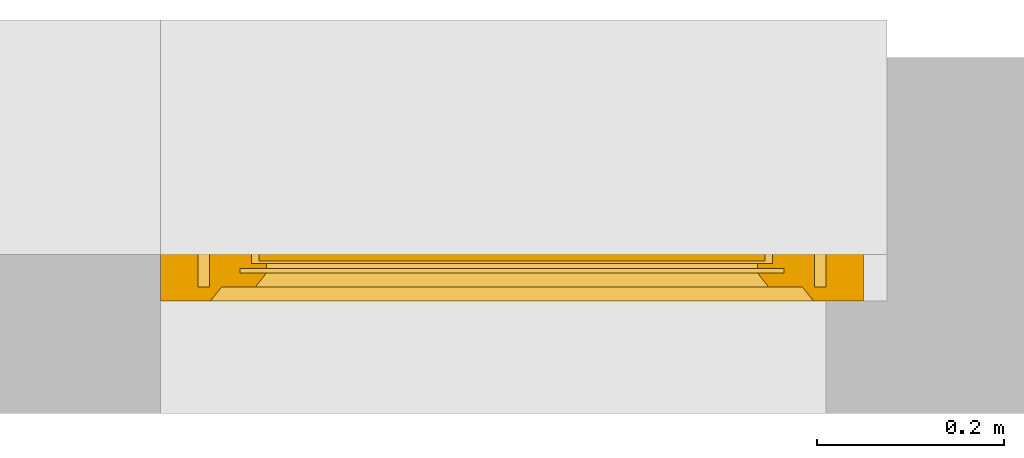
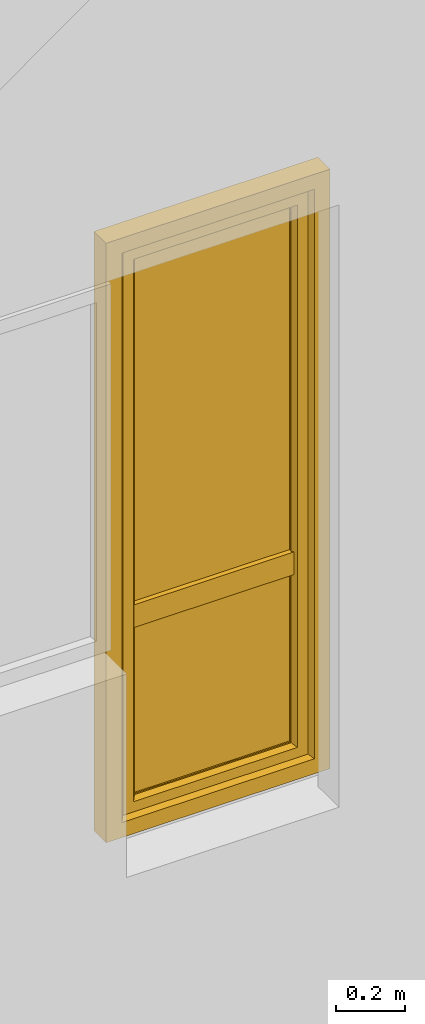
# One storey, part 3 of 4: 1 window.
"""IFC2X3 building model written with IfcOpenShell, lengths in millimetres."""

from ifc_helpers import new_model, entity, si_unit, converted_unit, derived_unit, direction, frame, origin, place, context, subcontext, project, spatial, faceted_brep, source, transform, mapped, material, material_list, type_object, type_shapes, element, save


model = new_model("IFC2X3")

# Units and contexts
model_context = context("Model", 3, precision=0.01, world=origin(), true_north=direction((6.12303176911189e-17, 1.0)))
context_of_model = context(None, 3, precision=0.01, world=origin(), true_north=direction((6.12303176911189e-17, 1.0)))
body_context = subcontext(model_context, "Body", "Model", "MODEL_VIEW")
ifc_project = project(units=[si_unit("LENGTHUNIT", "METRE", prefix="MILLI"), si_unit("AREAUNIT", "SQUARE_METRE"), si_unit("VOLUMEUNIT", "CUBIC_METRE"), converted_unit("PLANEANGLEUNIT", "DEGREE", entity("IfcRatioMeasure", 0.0174532925199433), si_unit("PLANEANGLEUNIT", "RADIAN"), dimensions=[0, 0, 0, 0, 0, 0, 0]), si_unit("MASSUNIT", "GRAM", prefix="KILO"), si_unit("TIMEUNIT", "SECOND"), si_unit("FREQUENCYUNIT", "HERTZ"), si_unit("THERMODYNAMICTEMPERATUREUNIT", "DEGREE_CELSIUS"), derived_unit("THERMALTRANSMITTANCEUNIT", [(si_unit("MASSUNIT", "GRAM", prefix="KILO"), 1), (si_unit("THERMODYNAMICTEMPERATUREUNIT", "KELVIN"), -1), (si_unit("TIMEUNIT", "SECOND"), -3)]), derived_unit("VOLUMETRICFLOWRATEUNIT", [(si_unit("LENGTHUNIT", "METRE"), 3), (si_unit("TIMEUNIT", "SECOND"), -1)]), si_unit("ELECTRICCURRENTUNIT", "AMPERE"), si_unit("ELECTRICVOLTAGEUNIT", "VOLT"), si_unit("POWERUNIT", "WATT"), si_unit("FORCEUNIT", "NEWTON", prefix="KILO"), si_unit("ILLUMINANCEUNIT", "LUX"), si_unit("LUMINOUSFLUXUNIT", "LUMEN"), si_unit("LUMINOUSINTENSITYUNIT", "CANDELA"), si_unit("PRESSUREUNIT", "PASCAL")], contexts=[model_context, context_of_model])

# Site, building, storey
site_placement = place(None, origin())
site = spatial("IfcSite", under=ifc_project, at=site_placement, CompositionType="ELEMENT")
building_placement = place(site_placement, origin())
building = spatial("IfcBuilding", under=site, at=building_placement, CompositionType="ELEMENT")
storey_placement = place(building_placement, origin())
storey = spatial("IfcBuildingStorey", under=building, at=storey_placement, CompositionType="ELEMENT", Elevation=0.0)

# Window
ifc_material_1 = material()
ifc_material_2 = material()
ifc_material_3 = material(Name="Rubber, Black")
ifc_material_4 = material()
ifc_material_5 = material()
ifc_material_list_1 = material_list([ifc_material_1, ifc_material_2, ifc_material_3, ifc_material_4, ifc_material_5])
ifc_material_list_2 = material_list([ifc_material_1, ifc_material_2, ifc_material_3, ifc_material_4, ifc_material_5])
window_style = type_object("IfcWindowStyle", ConstructionType="NOTDEFINED", OperationType="NOTDEFINED", ParameterTakesPrecedence=False, Sizeable=False, material=ifc_material_list_2)
shared_shape = source(origin(), body_context, "Body", "Brep", [
    faceted_brep([(316.0, -95.0, 1078.0), (316.0, -95.0, 1042.0), (316.0, -87.0, 1042.0), (316.0, -87.0, 1078.0), (315.15676402479, -87.0, 1082.78534851355), (315.577781614141, -95.0, 1080.39432433825), (310.861553373239, -95.0, 1088.56228263263), (309.002027461202, -87.0, 1090.12318487168), (308.99898619598, -95.0, 1090.12494091651), (293.138446626755, -87.0, 1088.56228263264), (294.997972538791, -95.0, 1090.12318487168), (295.001013804014, -87.0, 1090.12494091651), (312.726377727296, -87.0, 1086.99693396951), (312.724120550498, -95.0, 1086.99962434876), (313.939841889391, -95.0, 1084.89413651262), (304.432995842998, -87.0, 1091.78696961731), (304.429537368807, -95.0, 1091.78757948931), (306.714261782393, -95.0, 1090.95626020291), (310.864202594249, -87.0, 1088.5600594206), (315.155563228286, -95.0, 1082.78864867647), (313.941570876043, -87.0, 1084.89114124153), (306.7175116521, -87.0, 1090.9550772445), (299.570462631187, -87.0, 1091.78757948931), (299.567004156995, -95.0, 1091.78696961731), (301.998270762901, -95.0, 1091.78727455331), (297.282488347893, -95.0, 1090.9550772445), (297.2857382176, -87.0, 1090.95626020291), (290.05842912395, -95.0, 1084.89114124153), (288.844436771708, -87.0, 1082.78864867647), (288.843235975203, -95.0, 1082.78534851355), (291.275879449496, -87.0, 1086.99962434876), (291.273622272698, -95.0, 1086.99693396951), (293.135797405744, -95.0, 1088.5600594206), (302.001729237092, -87.0, 1091.78727455331), (288.0, -95.0, 1078.0), (288.422218385852, -87.0, 1080.39432433825), (288.0, -87.0, 1078.0), (290.060158110602, -87.0, 1084.89413651262), (288.0, -95.0, 1042.0), (288.0, -87.0, 1042.0), (288.843235975203, -95.0, 1037.21465148647), (288.843235975203, -87.0, 1037.21465148647), (294.997972538791, -95.0, 1029.87681512833), (293.135797405744, -95.0, 1031.43994057942), (291.273622272697, -95.0, 1033.00306603051), (291.273622272697, -87.0, 1033.00306603051), (293.135797405744, -87.0, 1031.43994057942), (294.997972538791, -87.0, 1029.87681512833), (315.577781614141, -95.0, 1039.60567566177), (315.155563228285, -95.0, 1037.21135132354), (315.155563228285, -87.0, 1037.21135132354), (315.569082639737, -87.0, 1039.55634534639), (290.05842912395, -87.0, 1035.10885875849), (290.05842912395, -95.0, 1035.10885875849), (297.282488347893, -87.0, 1029.04492275552), (299.567004156995, -87.0, 1028.21303038271), (299.567004156995, -95.0, 1028.21303038271), (297.282488347893, -95.0, 1029.04492275552), (304.429537368807, -95.0, 1028.2124205107), (301.998270762901, -95.0, 1028.21272544671), (301.998270762901, -87.0, 1028.21272544671), (304.429537368807, -87.0, 1028.2124205107), (306.714261782393, -87.0, 1029.0437397971), (308.99898619598, -87.0, 1029.8750590835), (308.99898619598, -95.0, 1029.8750590835), (306.714261782393, -95.0, 1029.0437397971), (310.861553373238, -87.0, 1031.43771736738), (312.724120550497, -87.0, 1033.00037565126), (312.724120550497, -95.0, 1033.00037565126), (310.861553373238, -95.0, 1031.43771736738), (313.939841889391, -87.0, 1035.1058634874), (313.939841889391, -95.0, 1035.1058634874), (292.636038969318, -97.0, 1084.3639610307), (291.757359312877, -97.0, 1082.24264068714), (290.878679656437, -97.0, 1080.12132034358), (290.0, -97.0, 1078.0), (290.0, -97.0, 1042.0), (290.878679656437, -97.0, 1039.87867965644), (291.757359312877, -97.0, 1037.75735931288), (292.636038969318, -97.0, 1035.63603896932), (293.514718625758, -97.0, 1033.51471862576), (295.636038969318, -97.0, 1032.63603896932), (297.757359312877, -97.0, 1031.75735931288), (299.878679656437, -97.0, 1030.87867965644), (302.0, -97.0, 1030.0), (304.121320343556, -97.0, 1030.87867965644), (306.242640687116, -97.0, 1031.75735931288), (308.363961030676, -97.0, 1032.63603896932), (310.485281374235, -97.0, 1033.51471862576), (311.363961030676, -97.0, 1035.63603896932), (312.242640687116, -97.0, 1037.75735931288), (313.121320343556, -97.0, 1039.87867965644), (314.0, -97.0, 1042.0), (314.0, -97.0, 1078.0), (313.121320343556, -97.0, 1080.12132034358), (312.242640687116, -97.0, 1082.24264068714), (311.363961030676, -97.0, 1084.3639610307), (310.485281374235, -97.0, 1086.48528137426), (308.363961030676, -97.0, 1087.3639610307), (306.242640687116, -97.0, 1088.24264068714), (304.121320343556, -97.0, 1089.12132034358), (302.0, -97.0, 1090.0), (299.878679656437, -97.0, 1089.12132034358), (297.757359312877, -97.0, 1088.24264068714), (295.636038969318, -97.0, 1087.3639610307), (293.514718625758, -97.0, 1086.48528137426), (290.0, -85.0, 1078.0), (290.878679656437, -85.0, 1080.12132034358), (291.757359312877, -85.0, 1082.24264068714), (292.636038969318, -85.0, 1084.3639610307), (293.514718625758, -85.0, 1086.48528137426), (295.636038969318, -85.0, 1087.3639610307), (297.757359312877, -85.0, 1088.24264068714), (299.878679656437, -85.0, 1089.12132034358), (302.0, -85.0, 1090.0), (304.121320343556, -85.0, 1089.12132034358), (306.242640687116, -85.0, 1088.24264068714), (308.363961030676, -85.0, 1087.3639610307), (310.485281374235, -85.0, 1086.48528137426), (311.363961030676, -85.0, 1084.3639610307), (312.242640687116, -85.0, 1082.24264068714), (313.121320343556, -85.0, 1080.12132034358), (314.0, -85.0, 1078.0), (314.0, -85.0, 1042.0), (313.121320343556, -85.0, 1039.87867965644), (312.242640687116, -85.0, 1037.75735931288), (311.363961030676, -85.0, 1035.63603896932), (310.485281374235, -85.0, 1033.51471862576), (308.363961030676, -85.0, 1032.63603896932), (306.242640687116, -85.0, 1031.75735931288), (304.121320343556, -85.0, 1030.87867965644), (302.0, -85.0, 1030.0), (299.878679656437, -85.0, 1030.87867965644), (297.757359312877, -85.0, 1031.75735931288), (295.636038969318, -85.0, 1032.63603896932), (293.514718625758, -85.0, 1033.51471862576), (292.636038969318, -85.0, 1035.63603896932), (291.757359312877, -85.0, 1037.75735931288), (290.878679656437, -85.0, 1039.87867965644), (290.0, -85.0, 1042.0)], [[[0, 1, 2, 3]], [[4, 5, 3]], [[6, 7, 8]], [[9, 10, 11]], [[12, 13, 14]], [[15, 16, 17]], [[7, 6, 18]], [[5, 0, 3]], [[18, 6, 13]], [[14, 19, 20]], [[4, 19, 5]], [[15, 17, 21]], [[8, 21, 17]], [[12, 14, 20]], [[22, 23, 24]], [[25, 11, 10]], [[26, 23, 22]], [[27, 28, 29]], [[21, 8, 7]], [[20, 19, 4]], [[30, 31, 32]], [[33, 16, 15]], [[34, 35, 36]], [[11, 25, 26]], [[23, 26, 25]], [[37, 27, 31]], [[32, 10, 9]], [[29, 28, 35]], [[30, 32, 9]], [[34, 29, 35]], [[28, 27, 37]], [[18, 13, 12]], [[33, 24, 16]], [[37, 31, 30]], [[22, 24, 33]], [[38, 34, 36, 39]], [[40, 38, 39, 41]], [[42, 43, 44, 45, 46, 47]], [[2, 1, 48, 49, 50, 51]], [[41, 52, 45, 44, 53, 40]], [[47, 54, 55, 56, 57, 42]], [[58, 59, 56, 55, 60, 61]], [[61, 62, 63, 64, 65, 58]], [[66, 67, 68, 69, 64, 63]], [[67, 70, 50, 49, 71, 68]], [[72, 73, 74, 75, 76, 77, 78, 79, 80, 81, 82, 83, 84, 85, 86, 87, 88, 89, 90, 91, 92, 93, 94, 95, 96, 97, 98, 99, 100, 101, 102, 103, 104, 105]], [[92, 48, 1]], [[48, 92, 91]], [[71, 49, 90]], [[44, 79, 53]], [[90, 49, 91]], [[78, 40, 53]], [[88, 68, 89]], [[88, 69, 68]], [[69, 87, 64]], [[89, 68, 71]], [[82, 57, 83]], [[91, 49, 48]], [[65, 85, 58]], [[82, 42, 57]], [[56, 84, 83]], [[65, 64, 86]], [[56, 83, 57]], [[76, 38, 77]], [[58, 84, 56, 59]], [[80, 44, 43]], [[85, 65, 86]], [[40, 77, 38]], [[82, 81, 42]], [[40, 78, 77]], [[43, 81, 80]], [[71, 90, 89]], [[87, 69, 88]], [[79, 44, 80]], [[79, 78, 53]], [[87, 86, 64]], [[85, 84, 58]], [[43, 42, 81]], [[92, 1, 0, 93]], [[72, 31, 27]], [[34, 74, 29]], [[27, 29, 73]], [[13, 96, 14]], [[74, 73, 29]], [[95, 19, 14]], [[104, 32, 105]], [[105, 32, 31]], [[32, 104, 10]], [[105, 31, 72]], [[99, 17, 100]], [[74, 34, 75]], [[25, 102, 23]], [[99, 8, 17]], [[16, 101, 100]], [[25, 10, 103]], [[16, 100, 17]], [[5, 93, 0]], [[99, 98, 8]], [[97, 13, 6]], [[93, 5, 94]], [[102, 25, 103]], [[94, 5, 19]], [[24, 23, 101, 16]], [[27, 73, 72]], [[96, 13, 97]], [[6, 98, 97]], [[96, 95, 14]], [[104, 103, 10]], [[102, 101, 23]], [[6, 8, 98]], [[94, 19, 95]], [[75, 34, 38, 76]], [[106, 107, 108, 109, 110, 111, 112, 113, 114, 115, 116, 117, 118, 119, 120, 121, 122, 123, 124, 125, 126, 127, 128, 129, 130, 131, 132, 133, 134, 135, 136, 137, 138, 139]], [[136, 45, 52]], [[39, 138, 41]], [[52, 41, 137]], [[67, 126, 70]], [[138, 137, 41]], [[125, 50, 70]], [[134, 46, 135]], [[135, 46, 45]], [[46, 134, 47]], [[135, 45, 136]], [[129, 62, 130]], [[138, 39, 139]], [[54, 132, 55]], [[129, 63, 62]], [[61, 131, 130]], [[54, 47, 133]], [[61, 130, 62]], [[51, 123, 2]], [[129, 128, 63]], [[127, 67, 66]], [[123, 51, 124]], [[132, 54, 133]], [[124, 51, 50]], [[60, 55, 131, 61]], [[52, 137, 136]], [[126, 67, 127]], [[66, 128, 127]], [[126, 125, 70]], [[134, 133, 47]], [[132, 131, 55]], [[66, 63, 128]], [[124, 50, 125]], [[122, 3, 2, 123]], [[119, 12, 20]], [[3, 121, 4]], [[20, 4, 120]], [[30, 109, 37]], [[121, 120, 4]], [[108, 28, 37]], [[117, 18, 118]], [[118, 18, 12]], [[18, 117, 7]], [[118, 12, 119]], [[112, 26, 113]], [[121, 3, 122]], [[21, 115, 15]], [[112, 11, 26]], [[22, 114, 113]], [[21, 7, 116]], [[22, 113, 26]], [[35, 106, 36]], [[112, 111, 11]], [[110, 30, 9]], [[106, 35, 107]], [[115, 21, 116]], [[107, 35, 28]], [[33, 15, 114, 22]], [[20, 120, 119]], [[109, 30, 110]], [[9, 111, 110]], [[109, 108, 37]], [[117, 116, 7]], [[115, 114, 15]], [[9, 11, 111]], [[107, 28, 108]], [[139, 39, 36, 106]]]),
    faceted_brep([(296.708497377884, -145.276775255392, 1000.52114796616), (307.291502622141, -145.276775255393, 1000.52114796616), (307.291502622141, -140.837885234758, 1042.66882878318), (296.708497377883, -140.837885234757, 1042.66882878318), (309.483314773561, -136.448348130646, 1000.52114796616), (309.483314773561, -132.203155672521, 1040.82965209673), (302.0, -131.276775255392, 1000.52114796616), (302.0, -127.145048202385, 1039.75228733741), (294.516685226465, -136.448348130645, 1000.52114796616), (294.516685226465, -132.203155672519, 1040.82965209673), (296.708497377884, -140.837885234758, 958.373467149146), (307.291502622141, -140.837885234758, 958.373467149146), (309.483314773561, -132.203155672522, 960.212643835597), (302.0, -127.145048202386, 961.290008594919), (294.516685226465, -132.20315567252, 960.212643835597)], [[[0, 1, 2, 3]], [[1, 4, 5, 2]], [[4, 6, 7, 5]], [[6, 8, 9, 7]], [[8, 0, 3, 9]], [[10, 11, 1, 0]], [[11, 12, 4, 1]], [[12, 13, 6, 4]], [[13, 14, 8, 6]], [[14, 10, 0, 8]], [[3, 2, 5, 7, 9]], [[14, 13, 12, 11, 10]]]),
    faceted_brep([(292.051080683025, -97.0, 1060.94591729901), (292.611695558692, -97.0, 1063.43924096907), (293.789262063046, -97.0, 1065.70333478471), (295.505173853981, -97.0, 1067.59726390535), (297.641101056472, -97.0, 1069.0), (302.0, -97.0, 1069.0), (306.358898943553, -97.0, 1069.0), (308.494826146044, -97.0, 1067.59726390535), (310.21073793698, -97.0, 1065.70333478471), (311.388304441334, -97.0, 1063.43924096907), (311.948919317001, -97.0, 1060.94591729901), (311.869095465839, -97.0, 1058.3919203214), (311.13720137139, -97.0, 1055.94604186494), (309.809455511885, -97.0, 1053.7614130413), (307.977034792575, -97.0, 1051.98307257928), (305.748005777723, -97.0, 1050.73512735946), (303.276299409612, -97.0, 1050.08403873227), (300.723700590414, -97.0, 1050.08403873227), (298.251994222303, -97.0, 1050.73512735946), (296.022965207451, -97.0, 1051.98307257928), (294.190544488141, -97.0, 1053.7614130413), (292.862798628635, -97.0, 1055.94604186494), (292.130904534187, -97.0, 1058.3919203214), (295.36991581395, -139.571199871011, 1041.81582813483), (294.455342623675, -138.066781139833, 1040.80273507336), (294.030329599176, -136.42046719477, 1039.69408812541), (294.118270668724, -134.736601923398, 1038.56015367782), (294.711981983899, -133.126161127661, 1037.47566412563), (295.779977969687, -131.692818084303, 1036.51043425854), (297.244878178697, -130.525776486187, 1035.72453488026), (299.018969835825, -129.706502117789, 1035.17282599704), (300.984995625036, -129.280982287031, 1034.88627599661), (303.01500437499, -129.280982287031, 1034.88627599661), (304.981030164201, -129.706502117789, 1035.17282599704), (306.755121821329, -130.525776486188, 1035.72453488026), (308.220022030338, -131.692818084303, 1036.51043425854), (309.288018016127, -133.126161127661, 1037.47566412563), (309.881729331302, -134.736601923398, 1038.56015367782), (309.96967040085, -136.420467194771, 1039.69408812541), (309.54465737635, -138.066781139833, 1040.80273507336), (308.630084186075, -139.571199871011, 1041.81582813483), (307.291502622142, -140.838667192924, 1042.6693553629), (303.793105551717, -140.838667192924, 1042.6693553629), (300.250801464801, -140.838667192924, 1042.6693553629), (296.708497377884, -140.838667192924, 1042.6693553629), (304.529498880468, -126.416323041036, 1058.53479166182), (302.0, -123.592503743986, 1060.46960324719), (302.021952862176, -133.930955778539, 1051.86725150298), (307.172590608633, -136.56784382523, 1047.7486255059), (304.753775786842, -134.00299976312, 1051.79007956711), (299.620924952884, -127.567125778351, 1057.66721198755), (299.76284265702, -119.178161613072, 1063.00337884315), (297.019365270747, -129.673589570168, 1055.9479296637), (299.158053189184, -134.921809886446, 1050.7785343575), (300.968325204554, -110.940739168215, 1066.41174131507), (297.330233163609, -114.56747742195, 1065.10298096761), (304.092059118563, -106.916614530037, 1067.54270145077), (306.980634729279, -129.673589570169, 1055.9479296637), (306.669766836416, -114.56747742195, 1065.10298096761), (310.334452629883, -129.075791149345, 1045.92276589624), (310.867926170591, -116.519842499668, 1058.07942490617), (311.45909914594, -107.240572966488, 1060.08550854294), (305.914032313248, -125.260625550182, 1040.68801313964), (307.61971635533, -120.444255008249, 1045.78506579307), (295.025209910725, -123.255273619451, 1045.70424775683), (292.982283480892, -115.101506888561, 1058.22389640407), (295.181117178989, -112.022437290098, 1050.92399318817), (308.844034150269, -109.417405225703, 1051.67364545902), (310.735407406298, -123.544355953025, 1052.17506192804), (292.693149579825, -106.118963862214, 1056.84627828438), (299.470198466739, -104.684687559105, 1049.97313305255)], [[[0, 1, 2, 3, 4, 5, 6, 7, 8, 9, 10, 11, 12, 13, 14, 15, 16, 17, 18, 19, 20, 21, 22]], [[23, 24, 25, 26, 27, 28, 29, 30, 31, 32, 33, 34, 35, 36, 37, 38, 39, 40, 41, 42, 43, 44]], [[45, 46, 47]], [[42, 41, 48]], [[49, 45, 47]], [[50, 46, 51]], [[50, 51, 52]], [[43, 47, 53]], [[53, 50, 52]], [[54, 4, 55]], [[44, 43, 53]], [[56, 6, 5]], [[48, 49, 42]], [[42, 47, 43]], [[49, 48, 57]], [[5, 54, 56]], [[49, 57, 45]], [[42, 49, 47]], [[57, 58, 45]], [[58, 46, 45]], [[50, 47, 46]], [[44, 53, 52]], [[47, 50, 53]], [[46, 54, 51]], [[56, 46, 58]], [[4, 54, 5]], [[54, 55, 51]], [[52, 51, 55]], [[46, 56, 54]], [[6, 56, 58]], [[40, 59, 41]], [[39, 38, 59]], [[59, 40, 39]], [[36, 59, 37]], [[60, 61, 58]], [[35, 34, 62]], [[62, 59, 36]], [[59, 62, 63]], [[33, 62, 34]], [[35, 62, 36]], [[38, 37, 59]], [[9, 8, 61]], [[61, 10, 9]], [[64, 65, 66]], [[8, 7, 61]], [[58, 7, 6]], [[58, 61, 7]], [[63, 67, 68]], [[67, 13, 61]], [[52, 55, 65]], [[67, 60, 68]], [[31, 62, 32]], [[59, 68, 57]], [[13, 67, 14]], [[65, 69, 66]], [[10, 61, 11]], [[11, 61, 12]], [[69, 55, 1]], [[16, 70, 17]], [[33, 32, 62]], [[66, 67, 63]], [[69, 70, 66]], [[67, 66, 70]], [[70, 15, 67]], [[29, 64, 30]], [[27, 64, 28]], [[64, 29, 28]], [[65, 64, 52]], [[25, 24, 64]], [[57, 60, 58]], [[64, 24, 52]], [[23, 44, 52]], [[67, 61, 60]], [[23, 52, 24]], [[64, 26, 25]], [[69, 65, 55]], [[63, 64, 66]], [[69, 20, 19]], [[69, 21, 20]], [[61, 13, 12]], [[60, 57, 68]], [[70, 16, 15]], [[17, 70, 18]], [[68, 59, 63]], [[62, 64, 63]], [[19, 18, 70]], [[69, 1, 0]], [[0, 22, 69]], [[1, 55, 2]], [[30, 62, 31]], [[64, 27, 26]], [[3, 2, 55]], [[4, 3, 55]], [[19, 70, 69]], [[15, 14, 67]], [[21, 69, 22]], [[59, 57, 48, 41]], [[64, 62, 30]]]),
    faceted_brep([(323.0, -15.0, 2068.0), (323.0, -70.0, 2068.0), (323.0, -70.0, 52.0), (323.0, -15.0, 52.0), (262.000081964466, -30.0, 2007.00008196447), (274.0, -15.0, 2019.0), (274.0, -15.0, 101.0), (262.000081964466, -30.0, 112.999918035527), (290.0, -72.0, 2035.0), (290.0, -30.0, 2035.0), (290.0, -30.0, 85.0), (290.0, -72.0, 85.0), (274.0, -84.0, 2019.0), (262.0, -72.0, 2007.0), (262.0, -72.0, 113.0), (274.0, -84.0, 101.0), (287.0, -85.0, 2032.0), (287.0, -84.0, 2032.0), (287.0, -84.0, 88.0), (287.0, -85.0, 88.0), (343.0, -83.0, 2088.0), (341.0, -85.0, 2086.0), (341.0, -85.0, 34.0), (343.0, -83.0, 32.0), (343.0, -70.0, 2088.0), (343.0, -70.0, 32.0), (-323.0, -70.0, 52.0), (-323.0, -15.0, 52.0), (-274.0, -15.0, 101.0), (-262.000081964469, -30.0, 112.999918035527), (-290.0, -30.0, 85.0), (-290.0, -72.0, 85.0), (-262.0, -72.0, 113.0), (-274.0, -84.0, 101.0), (-287.0, -84.0, 88.0), (-287.0, -85.0, 88.0), (-341.0, -85.0, 34.0), (-343.0, -83.0, 32.0), (-343.0, -70.0, 32.0), (-323.0, -70.0, 2068.0), (-323.0, -15.0, 2068.0), (-274.0, -15.0, 2019.0), (-262.000081964469, -30.0, 2007.00008196447), (-290.0, -30.0, 2035.0), (-290.0, -72.0, 2035.0), (-262.0, -72.0, 2007.0), (-274.0, -84.0, 2019.0), (-287.0, -84.0, 2032.0), (-287.0, -85.0, 2032.0), (-341.0, -85.0, 2086.0), (-343.0, -83.0, 2088.0), (-343.0, -70.0, 2088.0)], [[[0, 1, 2, 3]], [[4, 5, 6, 7]], [[8, 9, 10, 11]], [[12, 13, 14, 15]], [[16, 17, 18, 19]], [[20, 21, 22, 23]], [[24, 20, 23, 25]], [[3, 2, 26, 27]], [[7, 6, 28, 29]], [[11, 10, 30, 31]], [[15, 14, 32, 33]], [[19, 18, 34, 35]], [[23, 22, 36, 37]], [[25, 23, 37, 38]], [[27, 26, 39, 40]], [[29, 28, 41, 42]], [[31, 30, 43, 44]], [[33, 32, 45, 46]], [[35, 34, 47, 48]], [[37, 36, 49, 50]], [[38, 37, 50, 51]], [[40, 39, 1, 0]], [[3, 27, 40, 0], [5, 41, 28, 6]], [[42, 41, 5, 4]], [[7, 29, 42, 4], [9, 43, 30, 10]], [[44, 43, 9, 8]], [[11, 31, 44, 8], [13, 45, 32, 14]], [[46, 45, 13, 12]], [[15, 33, 46, 12], [17, 47, 34, 18]], [[48, 47, 17, 16]], [[19, 35, 48, 16], [21, 49, 36, 22]], [[50, 49, 21, 20]], [[51, 50, 20, 24]], [[1, 39, 26, 2], [25, 38, 51, 24]]], outer=[[True], [True], [True], [True], [True], [True], [True], [True], [True], [True], [True], [True], [True], [True], [True], [True], [True], [True], [True], [True], [True], [True], [True, False], [True], [False, True], [True], [True, False], [True], [False, True], [True], [False, True], [True], [True], [False, True]]),
    faceted_brep([(-290.0, -67.0, 85.0), (-290.0, -35.0, 85.0), (290.0, -35.0, 85.0), (290.0, -67.0, 85.0), (-262.0, -62.0, 113.0), (-262.0, -67.0, 113.0), (262.0, -67.0, 113.0), (262.0, -62.0, 113.0), (-278.0, -40.0, 97.0), (-278.0, -62.0, 97.0), (278.0, -62.0, 97.0), (278.0, -40.0, 97.0), (-262.0, -35.0, 113.0), (-262.0, -40.0, 113.0), (262.0, -40.0, 113.0), (262.0, -35.0, 113.0), (290.0, -35.0, 2035.0), (290.0, -67.0, 2035.0), (262.0, -67.0, 2007.0), (262.0, -62.0, 2007.0), (278.0, -62.0, 2023.0), (278.0, -40.0, 2023.0), (262.0, -40.0, 2007.0), (262.0, -35.0, 2007.0), (-290.0, -35.0, 2035.0), (-290.0, -67.0, 2035.0), (-262.0, -67.0, 2007.0), (-262.0, -62.0, 2007.0), (-278.0, -62.0, 2023.0), (-278.0, -40.0, 2023.0), (-262.0, -40.0, 2007.0), (-262.0, -35.0, 2007.0)], [[[0, 1, 2, 3]], [[4, 5, 6, 7]], [[8, 9, 10, 11]], [[12, 13, 14, 15]], [[3, 2, 16, 17]], [[7, 6, 18, 19]], [[11, 10, 20, 21]], [[15, 14, 22, 23]], [[17, 16, 24, 25]], [[19, 18, 26, 27]], [[21, 20, 28, 29]], [[23, 22, 30, 31]], [[15, 23, 31, 12], [1, 24, 16, 2]], [[25, 24, 1, 0]], [[3, 17, 25, 0], [5, 26, 18, 6]], [[27, 26, 5, 4]], [[7, 19, 27, 4], [9, 28, 20, 10]], [[29, 28, 9, 8]], [[11, 21, 29, 8], [13, 30, 22, 14]], [[31, 30, 13, 12]]], outer=[[True], [True], [True], [True], [True], [True], [True], [True], [True], [True], [True], [True], [False, True], [True], [True, False], [True], [False, True], [True], [True, False], [True]]),
    faceted_brep([(270.0, -65.0, 105.0), (270.0, -65.0, 710.0), (-270.0, -65.0, 710.0), (-270.0, -65.0, 105.0), (270.0, -43.0, 105.0), (-270.0, -43.0, 105.0), (-270.0, -43.0, 710.0), (270.0, -43.0, 710.0)], [[[0, 1, 2, 3]], [[4, 5, 6, 7]], [[1, 0, 4, 7]], [[2, 1, 7, 6]], [[3, 2, 6, 5]], [[0, 3, 5, 4]]]),
    faceted_brep([(-270.0, -62.0, 2019.0), (-270.0, -62.0, 770.0), (274.0, -62.0, 770.0), (274.0, -62.0, 2019.0), (-270.0, -40.0, 2019.0), (274.0, -40.0, 2019.0), (274.0, -40.0, 770.0), (-270.0, -40.0, 770.0)], [[[0, 1, 2, 3]], [[4, 5, 6, 7]], [[1, 0, 4, 7]], [[2, 1, 7, 6]], [[3, 2, 6, 5]], [[0, 3, 5, 4]]]),
    faceted_brep([(270.0, -23.0, 710.0), (270.0, -23.0, 790.0), (270.0, -85.0, 790.0), (270.0, -85.0, 710.0), (-270.0, -23.0, 790.0), (-270.0, -23.0, 710.0), (-270.0, -85.0, 710.0), (-270.0, -85.0, 790.0)], [[[0, 1, 2, 3]], [[4, 5, 6, 7]], [[2, 1, 4, 7]], [[2, 7, 6, 3]], [[0, 3, 6, 5]], [[0, 5, 4, 1]]]),
    faceted_brep([(-375.0, -70.0, 2120.0), (-375.0, 0.0, 2120.0), (-375.0, 0.0, 0.0), (-375.0, -70.0, 0.0), (-335.0, -15.0, 2080.0), (-335.0, -70.0, 2080.0), (-335.0, -70.0, 40.0), (-335.0, -15.0, 40.0), (-322.0, 0.0, 2067.0), (-310.0, -15.0, 2055.0), (-310.0, -15.0, 65.0), (-322.0, 0.0, 53.0), (375.0, 0.0, 0.0), (375.0, -70.0, 0.0), (335.0, -70.0, 40.0), (335.0, -15.0, 40.0), (310.0, -15.0, 65.0), (322.0, 0.0, 53.0), (375.0, 0.0, 2120.0), (375.0, -70.0, 2120.0), (335.0, -70.0, 2080.0), (335.0, -15.0, 2080.0), (310.0, -15.0, 2055.0), (322.0, 0.0, 2067.0)], [[[0, 1, 2, 3]], [[4, 5, 6, 7]], [[8, 9, 10, 11]], [[3, 2, 12, 13]], [[7, 6, 14, 15]], [[11, 10, 16, 17]], [[13, 12, 18, 19]], [[15, 14, 20, 21]], [[17, 16, 22, 23]], [[11, 17, 23, 8], [1, 18, 12, 2]], [[19, 18, 1, 0]], [[3, 13, 19, 0], [5, 20, 14, 6]], [[21, 20, 5, 4]], [[7, 15, 21, 4], [9, 22, 16, 10]], [[23, 22, 9, 8]]], outer=[[True], [True], [True], [True], [True], [True], [True], [True], [True], [False, True], [True], [True, False], [True], [True, False], [True]]),
])
type_shapes(window_style, [shared_shape])
window_placement = place(storey_placement, frame((-15009.3844562251, 12473.5585138251, 850.0), z_axis=(0.0, 0.0, 1.0), x_axis=(-1.0, 0.0, 0.0)))
element("IfcWindow", 1, at=window_placement, inside=storey, type_object=window_style, material=ifc_material_list_1, OverallHeight=2120.0, OverallWidth=910.000000000007, context=body_context, shape_type="MappedRepresentation", body=[
    mapped(shared_shape, transform((0.0, 0.0, 0.0), scale=1.0)),
])

save(model, "model.ifc")
